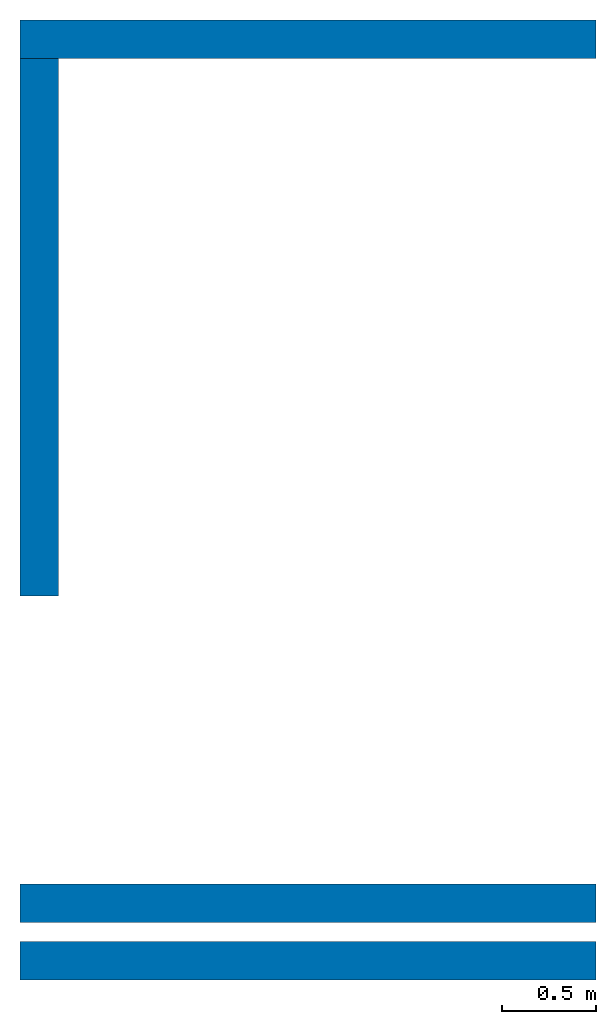
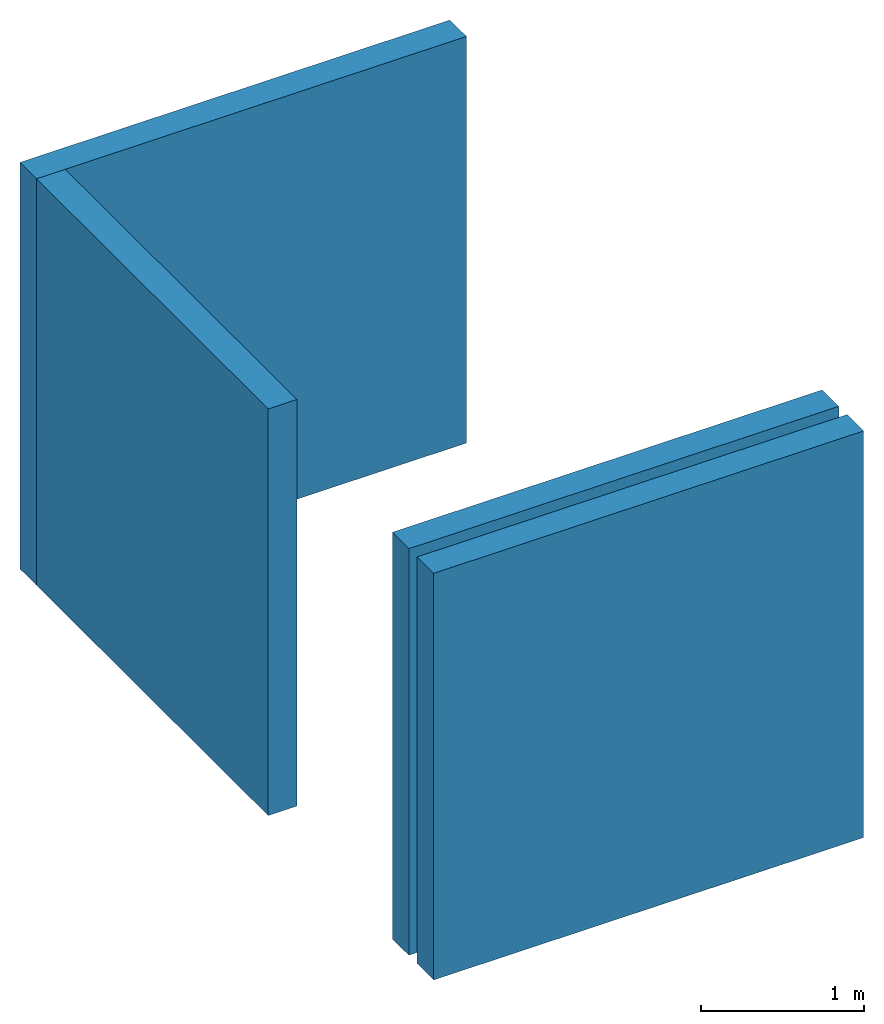
# One storey: 4 walls.
"""IFC4 building model written with IfcOpenShell, lengths in feet."""

from ifc_helpers import new_model, entity, si_unit, converted_unit, derived_unit, direction, frame, frame_2d, origin, place, context, subcontext, project, spatial, rectangle, extrude, material, layer, layer_set, layer_usage, type_object, element, save


model = new_model("IFC4")

# Units and contexts
model_context = context("Model", 3, precision=0.0001, world=origin(), true_north=direction((6.12303176911189e-17, 1.0)))
body_context = subcontext(model_context, "Body", "Model", "MODEL_VIEW")
ifc_project = project(units=[converted_unit("LENGTHUNIT", "FOOT", entity("IfcRatioMeasure", 0.3048), si_unit("LENGTHUNIT", "METRE"), dimensions=[1, 0, 0, 0, 0, 0, 0]), converted_unit("AREAUNIT", "SQUARE FOOT", entity("IfcRatioMeasure", 0.09290304), si_unit("AREAUNIT", "SQUARE_METRE"), dimensions=[2, 0, 0, 0, 0, 0, 0]), converted_unit("VOLUMEUNIT", "CUBIC FOOT", entity("IfcRatioMeasure", 0.028316846592), si_unit("VOLUMEUNIT", "CUBIC_METRE"), dimensions=[3, 0, 0, 0, 0, 0, 0]), converted_unit("PLANEANGLEUNIT", "DEGREE", entity("IfcRatioMeasure", 0.0174532925199433), si_unit("PLANEANGLEUNIT", "RADIAN"), dimensions=[0, 0, 0, 0, 0, 0, 0]), si_unit("MASSUNIT", "GRAM", prefix="KILO"), derived_unit("MASSDENSITYUNIT", [(si_unit("MASSUNIT", "GRAM", prefix="KILO"), 1), (si_unit("LENGTHUNIT", "METRE"), -3)]), si_unit("TIMEUNIT", "SECOND"), si_unit("FREQUENCYUNIT", "HERTZ"), si_unit("THERMODYNAMICTEMPERATUREUNIT", "DEGREE_CELSIUS"), derived_unit("THERMALTRANSMITTANCEUNIT", [(si_unit("MASSUNIT", "GRAM", prefix="KILO"), 1), (si_unit("THERMODYNAMICTEMPERATUREUNIT", "KELVIN"), -1), (si_unit("TIMEUNIT", "SECOND"), -3)]), derived_unit("VOLUMETRICFLOWRATEUNIT", [(si_unit("LENGTHUNIT", "METRE"), 3), (si_unit("TIMEUNIT", "SECOND"), -1)]), si_unit("ELECTRICCURRENTUNIT", "AMPERE"), si_unit("ELECTRICVOLTAGEUNIT", "VOLT"), si_unit("POWERUNIT", "WATT"), si_unit("FORCEUNIT", "NEWTON"), si_unit("ILLUMINANCEUNIT", "LUX"), si_unit("LUMINOUSFLUXUNIT", "LUMEN"), si_unit("LUMINOUSINTENSITYUNIT", "CANDELA"), derived_unit("USERDEFINED", [(si_unit("MASSUNIT", "GRAM", prefix="KILO"), -1), (si_unit("LENGTHUNIT", "METRE"), -2), (si_unit("TIMEUNIT", "SECOND"), 3), (si_unit("LUMINOUSFLUXUNIT", "LUMEN"), 1)]), derived_unit("LINEARVELOCITYUNIT", [(si_unit("LENGTHUNIT", "METRE"), 1), (si_unit("TIMEUNIT", "SECOND"), -1)]), si_unit("PRESSUREUNIT", "PASCAL"), derived_unit("USERDEFINED", [(si_unit("LENGTHUNIT", "METRE"), -2), (si_unit("MASSUNIT", "GRAM", prefix="KILO"), 1), (si_unit("TIMEUNIT", "SECOND"), -2)])], contexts=[model_context])

# Site, building, storey
site_placement = place(None, origin())
site = spatial("IfcSite", under=ifc_project, at=site_placement, CompositionType="ELEMENT")
building_placement = place(site_placement, origin())
building = spatial("IfcBuilding", under=site, at=building_placement, CompositionType="ELEMENT")
storey_placement = place(building_placement, origin())
storey = spatial("IfcBuildingStorey", under=building, at=storey_placement, Name="Level 1", CompositionType="ELEMENT", Elevation=0.0)

# Walls
ifc_material = material(Name="Default Wall", Category="Materials")
ifc_layer = layer(ifc_material, 0.666666666666667, Name="Default Wall", Category="Materials")
ifc_layer_set = layer_set([ifc_layer])
ifc_layer_usage_1 = layer_usage(ifc_layer_set, "AXIS2", "NEGATIVE", 0.333333333333333)
wall_type = type_object("IfcWallType", PredefinedType="NOTDEFINED", material=ifc_layer_set)
wall_1_placement = place(storey_placement, origin())
element("IfcWall", 1, at=wall_1_placement, inside=storey, type_object=wall_type, material=ifc_layer_usage_1, PredefinedType="NOTDEFINED", context=body_context, shape_type="SweptSolid", body=[
    extrude(rectangle(XDim=10.0, YDim=0.666666666666667, at=frame_2d((5.0, 0.0), x_axis=(-1.0, 0.0))), origin(), (0.0, 0.0, 1.0), 10.0),
])
ifc_layer_usage_2 = layer_usage(ifc_layer_set, "AXIS2", "NEGATIVE", 0.333333333333333)
wall_2_placement = place(storey_placement, frame((0.0, 1.0, 0.0)))
element("IfcWall", 2, at=wall_2_placement, inside=storey, type_object=wall_type, material=ifc_layer_usage_2, PredefinedType="NOTDEFINED", context=body_context, shape_type="SweptSolid", body=[
    extrude(rectangle(XDim=10.0, YDim=0.666666666666667, at=frame_2d((5.0, 2.77555756156289e-17), x_axis=(-1.0, 0.0))), origin(), (0.0, 0.0, 1.0), 10.0),
])
ifc_layer_usage_3 = layer_usage(ifc_layer_set, "AXIS2", "NEGATIVE", 0.333333333333333)
wall_3_placement = place(storey_placement, frame((0.0, 16.0, 0.0)))
element("IfcWall", 3, at=wall_3_placement, inside=storey, type_object=wall_type, material=ifc_layer_usage_3, PredefinedType="NOTDEFINED", context=body_context, shape_type="SweptSolid", body=[
    extrude(rectangle(XDim=10.0, YDim=0.666666666666666, at=frame_2d((5.0, -9.71445146547012e-16), x_axis=(-1.0, 0.0))), origin(), (0.0, 0.0, 1.0), 10.0),
])
ifc_layer_usage_4 = layer_usage(ifc_layer_set, "AXIS2", "POSITIVE", -0.333333333333333)
wall_4_placement = place(storey_placement, frame((0.33333333333336, 15.6666666666667, 0.0), z_axis=(0.0, 0.0, 1.0), x_axis=(0.0, -1.0, 0.0)))
element("IfcWall", 4, at=wall_4_placement, inside=storey, type_object=wall_type, material=ifc_layer_usage_4, PredefinedType="NOTDEFINED", context=body_context, shape_type="SweptSolid", body=[
    extrude(rectangle(XDim=9.33333333333333, YDim=0.666666666666667, at=frame_2d((4.66666666666667, -2.77555756156289e-17), x_axis=(-1.0, 0.0))), origin(), (0.0, 0.0, 1.0), 10.0),
])

save(model, "model.ifc")
